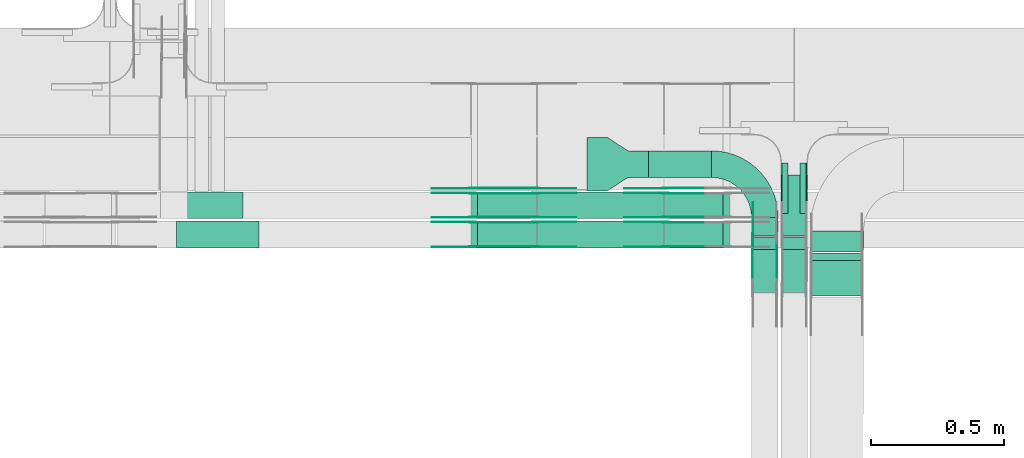
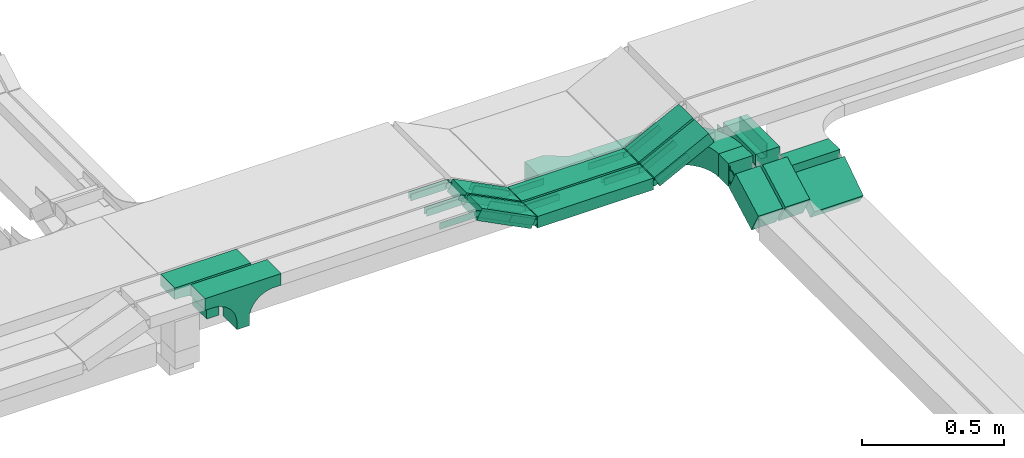
# One storey, part 22 of 27: 39 flow fittings, 13 flow segments.
"""IFC2X3 building model written with IfcOpenShell, lengths in millimetres."""

from ifc_helpers import new_model, entity, si_unit, converted_unit, derived_unit, direction, frame, frame_2d, origin, origin_2d_with_axis, place, context, subcontext, project, spatial, polyline, circle_curve, parameter, trimmed, segment, composite_curve, rectangle, outline, extrude, source, transform, mapped, material, type_object, type_shapes, element, save


model = new_model("IFC2X3")

# Units and contexts
model_context = context("Model", 3, precision=0.01, world=origin(), true_north=direction((6.12303176911189e-17, 1.0)))
body_context = subcontext(model_context, "Body", "Model", "MODEL_VIEW")
ifc_project = project(units=[si_unit("LENGTHUNIT", "METRE", prefix="MILLI"), si_unit("AREAUNIT", "SQUARE_METRE"), si_unit("VOLUMEUNIT", "CUBIC_METRE"), converted_unit("PLANEANGLEUNIT", "DEGREE", entity("IfcRatioMeasure", 0.0174532925199433), si_unit("PLANEANGLEUNIT", "RADIAN"), dimensions=[0, 0, 0, 0, 0, 0, 0]), si_unit("MASSUNIT", "GRAM", prefix="KILO"), derived_unit("MASSDENSITYUNIT", [(si_unit("MASSUNIT", "GRAM", prefix="KILO"), 1), (si_unit("LENGTHUNIT", "METRE"), -3)]), derived_unit("MOMENTOFINERTIAUNIT", [(si_unit("LENGTHUNIT", "METRE"), 4)]), si_unit("TIMEUNIT", "SECOND"), si_unit("FREQUENCYUNIT", "HERTZ"), si_unit("THERMODYNAMICTEMPERATUREUNIT", "DEGREE_CELSIUS"), derived_unit("THERMALTRANSMITTANCEUNIT", [(si_unit("MASSUNIT", "GRAM", prefix="KILO"), 1), (si_unit("THERMODYNAMICTEMPERATUREUNIT", "KELVIN"), -1), (si_unit("TIMEUNIT", "SECOND"), -3)]), derived_unit("VOLUMETRICFLOWRATEUNIT", [(si_unit("LENGTHUNIT", "METRE"), 3), (si_unit("TIMEUNIT", "SECOND"), -1)]), derived_unit("MASSFLOWRATEUNIT", [(si_unit("MASSUNIT", "GRAM", prefix="KILO"), 1), (si_unit("TIMEUNIT", "SECOND"), -1)]), derived_unit("ROTATIONALFREQUENCYUNIT", [(si_unit("TIMEUNIT", "SECOND"), -1)]), si_unit("ELECTRICCURRENTUNIT", "AMPERE"), si_unit("ELECTRICVOLTAGEUNIT", "VOLT"), si_unit("POWERUNIT", "WATT"), si_unit("FORCEUNIT", "NEWTON", prefix="KILO"), si_unit("ILLUMINANCEUNIT", "LUX"), si_unit("LUMINOUSFLUXUNIT", "LUMEN"), si_unit("LUMINOUSINTENSITYUNIT", "CANDELA"), derived_unit("USERDEFINED", [(si_unit("MASSUNIT", "GRAM", prefix="KILO"), -1), (si_unit("LENGTHUNIT", "METRE"), -2), (si_unit("TIMEUNIT", "SECOND"), 3), (si_unit("LUMINOUSFLUXUNIT", "LUMEN"), 1)]), derived_unit("LINEARVELOCITYUNIT", [(si_unit("LENGTHUNIT", "METRE"), 1), (si_unit("TIMEUNIT", "SECOND"), -1)]), si_unit("PRESSUREUNIT", "PASCAL"), derived_unit("USERDEFINED", [(si_unit("LENGTHUNIT", "METRE"), -2), (si_unit("MASSUNIT", "GRAM", prefix="KILO"), 1), (si_unit("TIMEUNIT", "SECOND"), -2)]), derived_unit("LINEARFORCEUNIT", [(si_unit("MASSUNIT", "GRAM", prefix="KILO"), 1), (si_unit("LENGTHUNIT", "METRE"), 1), (si_unit("TIMEUNIT", "SECOND"), -2), (si_unit("LENGTHUNIT", "METRE"), -1)]), derived_unit("PLANARFORCEUNIT", [(si_unit("MASSUNIT", "GRAM", prefix="KILO"), 1), (si_unit("LENGTHUNIT", "METRE"), 1), (si_unit("TIMEUNIT", "SECOND"), -2), (si_unit("LENGTHUNIT", "METRE"), -2)])], contexts=[model_context])

# Site, building, storey
site_placement = place(None, origin())
site = spatial("IfcSite", under=ifc_project, at=site_placement, CompositionType="ELEMENT")
building_placement = place(site_placement, origin())
building = spatial("IfcBuilding", under=site, at=building_placement, CompositionType="ELEMENT")
storey_placement = place(building_placement, origin())
storey = spatial("IfcBuildingStorey", under=building, at=storey_placement, CompositionType="ELEMENT", Elevation=0.0)

# Flow segments
cable_carrier_segment_type = type_object("IfcCableCarrierSegmentType", PredefinedType="CABLETRAYSEGMENT")
flow_segment_1_placement = place(storey_placement, frame((65838.17, 8564.33, 2600.0)))
element("IfcFlowSegment", 1, at=flow_segment_1_placement, inside=storey, type_object=cable_carrier_segment_type, context=body_context, shape_type="SweptSolid", body=[
    extrude(rectangle(XDim=235.827601762733, YDim=100.000000000001, at=origin_2d_with_axis()), frame((117.91, 50.0, 0.0)), (0.0, 0.0, 1.0), 100.0),
])
flow_segment_2_placement = place(storey_placement, frame((66225.0, 8344.23, 2600.0)))
element("IfcFlowSegment", 2, at=flow_segment_2_placement, inside=storey, type_object=cable_carrier_segment_type, context=body_context, shape_type="SweptSolid", body=[
    extrude(rectangle(XDim=69.0994138155711, YDim=99.9999999999946, at=origin_2d_with_axis()), frame((50.0, 34.55, 0.0), z_axis=(0.0, 0.0, 1.0), x_axis=(0.0, -1.0, 0.0)), (0.0, 0.0, 1.0), 100.0),
])
flow_segment_3_placement = place(storey_placement, frame((66225.0, 8133.28, 2512.93)))
element("IfcFlowSegment", 3, at=flow_segment_3_placement, inside=storey, type_object=cable_carrier_segment_type, context=body_context, shape_type="SweptSolid", body=[
    extrude(rectangle(XDim=100.0, YDim=99.9999999999946, at=origin_2d_with_axis()), frame((50.0, 23.73, 44.01), z_axis=(0.0, 0.880202910340005, 0.474597552278754), x_axis=(0.0, -0.474597552278754, 0.880202910340005)), (0.0, 0.0, 1.0), 181.443664845643),
])
flow_segment_4_placement = place(storey_placement, frame((66335.0, 8344.23, 2600.0)))
element("IfcFlowSegment", 4, at=flow_segment_4_placement, inside=storey, type_object=cable_carrier_segment_type, context=body_context, shape_type="SweptSolid", body=[
    extrude(rectangle(XDim=230.099413815084, YDim=99.9999999999946, at=origin_2d_with_axis()), frame((50.0, 115.05, 0.0), z_axis=(0.0, 0.0, 1.0), x_axis=(0.0, -1.0, 0.0)), (0.0, 0.0, 1.0), 100.0),
])
flow_segment_5_placement = place(storey_placement, frame((66335.0, 8133.28, 2512.93)))
element("IfcFlowSegment", 5, at=flow_segment_5_placement, inside=storey, type_object=cable_carrier_segment_type, context=body_context, shape_type="SweptSolid", body=[
    extrude(rectangle(XDim=99.9999999999998, YDim=99.9999999999946, at=origin_2d_with_axis()), frame((50.0, 23.73, 44.01), z_axis=(0.0, 0.880202910342462, 0.474597552274198), x_axis=(0.0, -0.474597552274198, 0.880202910342462)), (0.0, 0.0, 1.0), 181.443664845729),
])
flow_segment_6_placement = place(storey_placement, frame((66445.0, 8284.12, 2600.0)))
element("IfcFlowSegment", 6, at=flow_segment_6_placement, inside=storey, type_object=cable_carrier_segment_type, context=body_context, shape_type="SweptSolid", body=[
    extrude(rectangle(XDim=79.2028595795973, YDim=200.000000000007, at=origin_2d_with_axis()), frame((100.0, 39.6, 0.0), z_axis=(0.0, 0.0, 1.0), x_axis=(0.0, -1.0, 0.0)), (0.0, 0.0, 1.0), 49.9999999999995),
])
flow_segment_7_placement = place(storey_placement, frame((66445.0, 8118.93, 2509.66)))
element("IfcFlowSegment", 7, at=flow_segment_7_placement, inside=storey, type_object=cable_carrier_segment_type, context=body_context, shape_type="SweptSolid", body=[
    extrude(rectangle(XDim=49.9999999999992, YDim=160.399490584972, at=frame_2d((0.0, 0.0), x_axis=(0.0, 1.0))), frame((0.0, 80.57, 65.34), z_axis=(1.0, 0.0, 0.0), x_axis=(0.0, -0.831466573945081, -0.555574780215976)), (0.0, 0.0, 1.0), 200.000000000007),
])
flow_segment_8_placement = place(storey_placement, frame((65421.78, 8300.0, 2730.0)))
element("IfcFlowSegment", 8, at=flow_segment_8_placement, inside=storey, type_object=cable_carrier_segment_type, context=body_context, shape_type="SweptSolid", body=[
    extrude(rectangle(XDim=472.037715986993, YDim=100.000000000001, at=origin_2d_with_axis()), frame((236.02, 50.0, 0.0), z_axis=(0.0, 0.0, 1.0), x_axis=(-1.0, 0.0, 0.0)), (0.0, 0.0, 1.0), 50.0000000000005),
])
flow_segment_9_placement = place(storey_placement, frame((65897.53, 8300.0, 2736.34)))
element("IfcFlowSegment", 9, at=flow_segment_9_placement, inside=storey, type_object=cable_carrier_segment_type, context=body_context, shape_type="SweptSolid", body=[
    extrude(rectangle(XDim=49.9999999999994, YDim=99.9999999999989, at=frame_2d((0.0, 0.0), x_axis=(0.0, 1.0))), frame((11.35, 50.0, 22.28), z_axis=(0.89100652418826, 0.0, 0.453990499739758), x_axis=(0.0, 1.0, 0.0)), (0.0, 0.0, 1.0), 248.398143723743),
])
flow_segment_10_placement = place(storey_placement, frame((65174.05, 8300.0, 2736.34)))
element("IfcFlowSegment", 10, at=flow_segment_10_placement, inside=storey, type_object=cable_carrier_segment_type, context=body_context, shape_type="SweptSolid", body=[
    extrude(rectangle(XDim=50.0000000000027, YDim=99.9999999999989, at=origin_2d_with_axis()), frame((11.35, 50.0, 135.05), z_axis=(0.891006524188364, 0.0, -0.453990499739555), x_axis=(0.453990499739555, 0.0, 0.891006524188364)), (0.0, 0.0, 1.0), 248.39814372396),
])
flow_segment_11_placement = place(storey_placement, frame((65421.78, 8410.0, 2730.0)))
element("IfcFlowSegment", 11, at=flow_segment_11_placement, inside=storey, type_object=cable_carrier_segment_type, context=body_context, shape_type="SweptSolid", body=[
    extrude(rectangle(XDim=472.037715986993, YDim=99.9999999999989, at=origin_2d_with_axis()), frame((236.02, 50.0, 0.0), z_axis=(0.0, 0.0, 1.0), x_axis=(-1.0, 0.0, 0.0)), (0.0, 0.0, 1.0), 50.0000000000005),
])
flow_segment_12_placement = place(storey_placement, frame((65897.53, 8410.0, 2736.34)))
element("IfcFlowSegment", 12, at=flow_segment_12_placement, inside=storey, type_object=cable_carrier_segment_type, context=body_context, shape_type="SweptSolid", body=[
    extrude(rectangle(XDim=50.0000000000027, YDim=100.000000000001, at=frame_2d((0.0, 0.0), x_axis=(0.0, 1.0))), frame((11.35, 50.0, 22.28), z_axis=(0.891006524188364, 0.0, 0.453990499739555), x_axis=(0.0, 1.0, 0.0)), (0.0, 0.0, 1.0), 248.39814372396),
])
flow_segment_13_placement = place(storey_placement, frame((65174.05, 8410.0, 2736.34)))
element("IfcFlowSegment", 13, at=flow_segment_13_placement, inside=storey, type_object=cable_carrier_segment_type, context=body_context, shape_type="SweptSolid", body=[
    extrude(rectangle(XDim=49.9999999999978, YDim=100.000000000001, at=origin_2d_with_axis()), frame((11.35, 50.0, 135.05), z_axis=(0.891006524188517, 0.0, -0.453990499739253), x_axis=(0.453990499739253, 0.0, 0.891006524188517)), (0.0, 0.0, 1.0), 248.398143724083),
])

# Flow fittings
ifc_material_1 = material()
cable_carrier_fitting_type_1 = type_object("IfcCableCarrierFittingType", PredefinedType="NOTDEFINED", material=ifc_material_1)
shared_shape_1 = source(origin(), body_context, "Body", "SweptSolid", [
    extrude(outline(polyline([(-9.17, -21.5), (15.83, -21.5), (15.83, -19.0), (-6.67, -19.0), (-6.67, 40.5), (-9.17, 40.5), (-9.17, -21.5)])), frame((-95.0, 9.17, -26.0), z_axis=(1.0, 0.0, 0.0), x_axis=(0.0, 1.0, 0.0)), (0.0, 0.0, 1.0), 190.0),
])
type_shapes(cable_carrier_fitting_type_1, [shared_shape_1])
for number, where, z_axis, x_axis in (
    (14, (66432.5, 8524.33, 2650.0), (0.0, 0.0, 1.0), (0.0, 1.0, 0.0)),
    (15, (66337.5, 8524.33, 2650.0), (0.0, 0.0, 1.0), (0.0, -1.0, 0.0)),
):
    element("IfcFlowFitting", number, at=place(storey_placement, frame(where, z_axis=z_axis, x_axis=x_axis)), inside=storey, type_object=cable_carrier_fitting_type_1, material=ifc_material_1, context=body_context, shape_type="MappedRepresentation", body=[
        mapped(shared_shape_1, transform((0.0, 0.0, 0.0), scale=1.0)),
    ])
ifc_material_2 = material()
cable_carrier_fitting_type_2 = type_object("IfcCableCarrierFittingType", PredefinedType="NOTDEFINED", material=ifc_material_2)
shared_shape_2 = source(origin(), body_context, "Body", "SweptSolid", [
    extrude(outline(polyline([(-115.0, 50.0), (-115.0, -50.0), (-38.33, -50.0), (38.33, -100.0), (115.0, -100.0), (115.0, 100.0), (38.33, 100.0), (-38.33, 50.0), (-115.0, 50.0)])), frame((115.0, 0.0, -50.0), z_axis=(0.0, 0.0, -1.0), x_axis=(1.0, 0.0, 0.0)), (0.0, 0.0, -1.0), 100.0),
])
type_shapes(cable_carrier_fitting_type_2, [shared_shape_2])
flow_fitting_1_placement = place(storey_placement, frame((65838.17, 8614.33, 2650.0), z_axis=(0.0, 0.0, 1.0), x_axis=(-1.0, 0.0, 0.0)))
element("IfcFlowFitting", 16, at=flow_fitting_1_placement, inside=storey, type_object=cable_carrier_fitting_type_2, material=ifc_material_2, Name="470_DKC_S5_adapter", context=body_context, shape_type="MappedRepresentation", body=[
    mapped(shared_shape_2, transform((0.0, 0.0, 0.0), scale=1.0)),
])
ifc_material_3 = material(Name="G")
cable_carrier_fitting_type_3 = type_object("IfcCableCarrierFittingType", PredefinedType="NOTDEFINED", material=ifc_material_3)
shared_shape_3 = source(origin(), body_context, "Body", "SweptSolid", [
    extrude(outline(composite_curve([segment(trimmed(circle_curve(frame_2d((-44.59, 0.0), x_axis=(1.0, 0.0)), 12.5), [parameter(90.0000000000007)], [parameter(270.0)], True, "PARAMETER"), True, "CONTINUOUS"), segment(polyline([(-44.59, -12.5), (-33.09, -12.5)]), True, "CONTINUOUS"), segment(polyline([(-33.09, -12.5), (-31.23, -14.5)]), True, "CONTINUOUS"), segment(polyline([(-31.23, -14.5), (108.91, -14.5)]), True, "CONTINUOUS"), segment(polyline([(108.91, -14.5), (108.91, 14.5)]), True, "CONTINUOUS"), segment(polyline([(108.91, 14.5), (-31.23, 14.5)]), True, "CONTINUOUS"), segment(polyline([(-31.23, 14.5), (-33.09, 12.5)]), True, "CONTINUOUS"), segment(polyline([(-33.09, 12.5), (-44.59, 12.5)]), True, "CONTINUOUS")], self_intersect=False)), frame((44.59, 0.0, 0.0), z_axis=(0.0, 0.0, -1.0), x_axis=(1.0, 0.0, 0.0)), (0.0, 0.0, -1.0), 2.0),
])
type_shapes(cable_carrier_fitting_type_3, [shared_shape_3])
flow_fitting_2_placement = place(storey_placement, frame((65901.78, 8395.46, 2755.0), z_axis=(0.0, 1.0, 0.0), x_axis=(-1.0, 0.0, 0.0)))
element("IfcFlowFitting", 17, at=flow_fitting_2_placement, inside=storey, type_object=cable_carrier_fitting_type_3, material=ifc_material_3, context=body_context, shape_type="MappedRepresentation", body=[
    mapped(shared_shape_3, transform((0.0, 0.0, 0.0), scale=1.0)),
])
cable_carrier_fitting_type_4 = type_object("IfcCableCarrierFittingType", PredefinedType="NOTDEFINED", material=ifc_material_3)
type_shapes(cable_carrier_fitting_type_4, [shared_shape_3])
flow_fitting_3_placement = place(storey_placement, frame((65901.78, 8306.54, 2755.0), z_axis=(0.0, -1.0, 0.0), x_axis=(0.891006524188259, 0.0, 0.45399049973976)))
element("IfcFlowFitting", 18, at=flow_fitting_3_placement, inside=storey, type_object=cable_carrier_fitting_type_4, material=ifc_material_3, context=body_context, shape_type="MappedRepresentation", body=[
    mapped(shared_shape_3, transform((0.0, 0.0, 0.0), scale=1.0)),
])
flow_fitting_4_placement = place(storey_placement, frame((65413.82, 8304.54, 2755.0), z_axis=(0.0, -1.0, 0.0), x_axis=(1.0, 0.0, 0.0)))
element("IfcFlowFitting", 19, at=flow_fitting_4_placement, inside=storey, type_object=cable_carrier_fitting_type_3, material=ifc_material_3, context=body_context, shape_type="MappedRepresentation", body=[
    mapped(shared_shape_3, transform((0.0, 0.0, 0.0), scale=1.0)),
])
flow_fitting_5_placement = place(storey_placement, frame((65413.82, 8393.46, 2755.0), z_axis=(0.0, 1.0, 0.0), x_axis=(-0.891006524188259, 0.0, 0.45399049973976)))
element("IfcFlowFitting", 20, at=flow_fitting_5_placement, inside=storey, type_object=cable_carrier_fitting_type_4, material=ifc_material_3, context=body_context, shape_type="MappedRepresentation", body=[
    mapped(shared_shape_3, transform((0.0, 0.0, 0.0), scale=1.0)),
])
flow_fitting_6_placement = place(storey_placement, frame((65178.31, 8304.54, 2875.0), z_axis=(0.0, -1.0, 0.0), x_axis=(-1.0, 0.0, 0.0)))
element("IfcFlowFitting", 21, at=flow_fitting_6_placement, inside=storey, type_object=cable_carrier_fitting_type_3, material=ifc_material_3, context=body_context, shape_type="MappedRepresentation", body=[
    mapped(shared_shape_3, transform((0.0, 0.0, 0.0), scale=1.0)),
])
flow_fitting_7_placement = place(storey_placement, frame((65178.31, 8393.46, 2875.0), z_axis=(0.0, 1.0, 0.0), x_axis=(0.891006524188393, 0.0, -0.453990499739498)))
element("IfcFlowFitting", 22, at=flow_fitting_7_placement, inside=storey, type_object=cable_carrier_fitting_type_4, material=ifc_material_3, context=body_context, shape_type="MappedRepresentation", body=[
    mapped(shared_shape_3, transform((0.0, 0.0, 0.0), scale=1.0)),
])
flow_fitting_8_placement = place(storey_placement, frame((65901.78, 8505.46, 2755.0), z_axis=(0.0, 1.0, 0.0), x_axis=(-1.0, 0.0, 0.0)))
element("IfcFlowFitting", 23, at=flow_fitting_8_placement, inside=storey, type_object=cable_carrier_fitting_type_3, material=ifc_material_3, context=body_context, shape_type="MappedRepresentation", body=[
    mapped(shared_shape_3, transform((0.0, 0.0, 0.0), scale=1.0)),
])
flow_fitting_9_placement = place(storey_placement, frame((65901.78, 8416.54, 2755.0), z_axis=(0.0, -1.0, 0.0), x_axis=(0.891006524188259, 0.0, 0.45399049973976)))
element("IfcFlowFitting", 24, at=flow_fitting_9_placement, inside=storey, type_object=cable_carrier_fitting_type_4, material=ifc_material_3, context=body_context, shape_type="MappedRepresentation", body=[
    mapped(shared_shape_3, transform((0.0, 0.0, 0.0), scale=1.0)),
])
flow_fitting_10_placement = place(storey_placement, frame((65413.82, 8414.54, 2755.0), z_axis=(0.0, -1.0, 0.0), x_axis=(1.0, 0.0, 0.0)))
element("IfcFlowFitting", 25, at=flow_fitting_10_placement, inside=storey, type_object=cable_carrier_fitting_type_3, material=ifc_material_3, context=body_context, shape_type="MappedRepresentation", body=[
    mapped(shared_shape_3, transform((0.0, 0.0, 0.0), scale=1.0)),
])
for number, where, z_axis, x_axis in (
    (26, (65413.82, 8503.46, 2755.0), (0.0, 1.0, 0.0), (-0.891006524188259, 0.0, 0.45399049973976)),
    (27, (65901.78, 8526.54, 2755.0), (0.0, -1.0, 0.0), (0.891006524188259, 0.0, 0.45399049973976)),
):
    element("IfcFlowFitting", number, at=place(storey_placement, frame(where, z_axis=z_axis, x_axis=x_axis)), inside=storey, type_object=cable_carrier_fitting_type_4, material=ifc_material_3, context=body_context, shape_type="MappedRepresentation", body=[
        mapped(shared_shape_3, transform((0.0, 0.0, 0.0), scale=1.0)),
    ])
for number, where, z_axis, x_axis in (
    (28, (65413.82, 8524.54, 2755.0), (0.0, -1.0, 0.0), (1.0, 0.0, 0.0)),
    (29, (65178.31, 8524.54, 2875.0), (0.0, -1.0, 0.0), (-1.0, 0.0, 0.0)),
    (30, (65178.31, 8414.54, 2875.0), (0.0, -1.0, 0.0), (-1.0, 0.0, 0.0)),
):
    element("IfcFlowFitting", number, at=place(storey_placement, frame(where, z_axis=z_axis, x_axis=x_axis)), inside=storey, type_object=cable_carrier_fitting_type_3, material=ifc_material_3, context=body_context, shape_type="MappedRepresentation", body=[
        mapped(shared_shape_3, transform((0.0, 0.0, 0.0), scale=1.0)),
    ])
flow_fitting_11_placement = place(storey_placement, frame((65178.31, 8503.46, 2875.0), z_axis=(0.0, 1.0, 0.0), x_axis=(0.891006524188516, 0.0, -0.453990499739256)))
element("IfcFlowFitting", 31, at=flow_fitting_11_placement, inside=storey, type_object=cable_carrier_fitting_type_4, material=ifc_material_3, context=body_context, shape_type="MappedRepresentation", body=[
    mapped(shared_shape_3, transform((0.0, 0.0, 0.0), scale=1.0)),
])
cable_carrier_fitting_type_5 = type_object("IfcCableCarrierFittingType", PredefinedType="NOTDEFINED", material=ifc_material_3)
shared_shape_4 = source(origin(), body_context, "Body", "SweptSolid", [
    extrude(outline(composite_curve([segment(trimmed(circle_curve(frame_2d((-44.59, 0.0), x_axis=(1.0, 0.0)), 12.5), [parameter(90.0000000000007)], [parameter(270.0)], True, "PARAMETER"), True, "CONTINUOUS"), segment(polyline([(-44.59, -12.5), (-33.09, -12.5)]), True, "CONTINUOUS"), segment(polyline([(-33.09, -12.5), (-31.23, -14.5)]), True, "CONTINUOUS"), segment(polyline([(-31.23, -14.5), (108.91, -14.5)]), True, "CONTINUOUS"), segment(polyline([(108.91, -14.5), (108.91, 14.5)]), True, "CONTINUOUS"), segment(polyline([(108.91, 14.5), (-31.23, 14.5)]), True, "CONTINUOUS"), segment(polyline([(-31.23, 14.5), (-33.09, 12.5)]), True, "CONTINUOUS"), segment(polyline([(-33.09, 12.5), (-44.59, 12.5)]), True, "CONTINUOUS")], self_intersect=False)), frame((44.59, 0.0, 0.0)), (0.0, 0.0, 1.0), 2.0),
])
type_shapes(cable_carrier_fitting_type_5, [shared_shape_4])
flow_fitting_12_placement = place(storey_placement, frame((65901.78, 8304.54, 2755.0), z_axis=(0.0, -1.0, 0.0), x_axis=(-1.0, 0.0, 0.0)))
element("IfcFlowFitting", 32, at=flow_fitting_12_placement, inside=storey, type_object=cable_carrier_fitting_type_5, material=ifc_material_3, context=body_context, shape_type="MappedRepresentation", body=[
    mapped(shared_shape_4, transform((0.0, 0.0, 0.0), scale=1.0)),
])
cable_carrier_fitting_type_6 = type_object("IfcCableCarrierFittingType", PredefinedType="NOTDEFINED", material=ifc_material_3)
type_shapes(cable_carrier_fitting_type_6, [shared_shape_4])
flow_fitting_13_placement = place(storey_placement, frame((65901.78, 8393.46, 2755.0), z_axis=(0.0, 1.0, 0.0), x_axis=(0.891006524188259, 0.0, 0.45399049973976)))
element("IfcFlowFitting", 33, at=flow_fitting_13_placement, inside=storey, type_object=cable_carrier_fitting_type_6, material=ifc_material_3, context=body_context, shape_type="MappedRepresentation", body=[
    mapped(shared_shape_4, transform((0.0, 0.0, 0.0), scale=1.0)),
])
flow_fitting_14_placement = place(storey_placement, frame((65413.82, 8395.46, 2755.0), z_axis=(0.0, 1.0, 0.0), x_axis=(1.0, 0.0, 0.0)))
element("IfcFlowFitting", 34, at=flow_fitting_14_placement, inside=storey, type_object=cable_carrier_fitting_type_5, material=ifc_material_3, context=body_context, shape_type="MappedRepresentation", body=[
    mapped(shared_shape_4, transform((0.0, 0.0, 0.0), scale=1.0)),
])
flow_fitting_15_placement = place(storey_placement, frame((65413.82, 8306.54, 2755.0), z_axis=(0.0, -1.0, 0.0), x_axis=(-0.891006524188259, 0.0, 0.45399049973976)))
element("IfcFlowFitting", 35, at=flow_fitting_15_placement, inside=storey, type_object=cable_carrier_fitting_type_6, material=ifc_material_3, context=body_context, shape_type="MappedRepresentation", body=[
    mapped(shared_shape_4, transform((0.0, 0.0, 0.0), scale=1.0)),
])
flow_fitting_16_placement = place(storey_placement, frame((65178.31, 8395.46, 2875.0), z_axis=(0.0, 1.0, 0.0), x_axis=(-1.0, 0.0, 0.0)))
element("IfcFlowFitting", 36, at=flow_fitting_16_placement, inside=storey, type_object=cable_carrier_fitting_type_5, material=ifc_material_3, context=body_context, shape_type="MappedRepresentation", body=[
    mapped(shared_shape_4, transform((0.0, 0.0, 0.0), scale=1.0)),
])
flow_fitting_17_placement = place(storey_placement, frame((65178.31, 8306.54, 2875.0), z_axis=(0.0, -1.0, 0.0), x_axis=(0.891006524188393, 0.0, -0.453990499739498)))
element("IfcFlowFitting", 37, at=flow_fitting_17_placement, inside=storey, type_object=cable_carrier_fitting_type_6, material=ifc_material_3, context=body_context, shape_type="MappedRepresentation", body=[
    mapped(shared_shape_4, transform((0.0, 0.0, 0.0), scale=1.0)),
])
flow_fitting_18_placement = place(storey_placement, frame((65901.78, 8414.54, 2755.0), z_axis=(0.0, -1.0, 0.0), x_axis=(-1.0, 0.0, 0.0)))
element("IfcFlowFitting", 38, at=flow_fitting_18_placement, inside=storey, type_object=cable_carrier_fitting_type_5, material=ifc_material_3, context=body_context, shape_type="MappedRepresentation", body=[
    mapped(shared_shape_4, transform((0.0, 0.0, 0.0), scale=1.0)),
])
flow_fitting_19_placement = place(storey_placement, frame((65901.78, 8503.46, 2755.0), z_axis=(0.0, 1.0, 0.0), x_axis=(0.891006524188259, 0.0, 0.45399049973976)))
element("IfcFlowFitting", 39, at=flow_fitting_19_placement, inside=storey, type_object=cable_carrier_fitting_type_6, material=ifc_material_3, context=body_context, shape_type="MappedRepresentation", body=[
    mapped(shared_shape_4, transform((0.0, 0.0, 0.0), scale=1.0)),
])
flow_fitting_20_placement = place(storey_placement, frame((65413.82, 8505.46, 2755.0), z_axis=(0.0, 1.0, 0.0), x_axis=(1.0, 0.0, 0.0)))
element("IfcFlowFitting", 40, at=flow_fitting_20_placement, inside=storey, type_object=cable_carrier_fitting_type_5, material=ifc_material_3, context=body_context, shape_type="MappedRepresentation", body=[
    mapped(shared_shape_4, transform((0.0, 0.0, 0.0), scale=1.0)),
])
flow_fitting_21_placement = place(storey_placement, frame((65413.82, 8416.54, 2755.0), z_axis=(0.0, -1.0, 0.0), x_axis=(-0.891006524188259, 0.0, 0.45399049973976)))
element("IfcFlowFitting", 41, at=flow_fitting_21_placement, inside=storey, type_object=cable_carrier_fitting_type_6, material=ifc_material_3, context=body_context, shape_type="MappedRepresentation", body=[
    mapped(shared_shape_4, transform((0.0, 0.0, 0.0), scale=1.0)),
])
flow_fitting_22_placement = place(storey_placement, frame((65901.78, 8524.54, 2755.0), z_axis=(0.0, -1.0, 0.0), x_axis=(-1.0, 0.0, 0.0)))
element("IfcFlowFitting", 42, at=flow_fitting_22_placement, inside=storey, type_object=cable_carrier_fitting_type_5, material=ifc_material_3, context=body_context, shape_type="MappedRepresentation", body=[
    mapped(shared_shape_4, transform((0.0, 0.0, 0.0), scale=1.0)),
])
for number, where, z_axis, x_axis in (
    (43, (65413.82, 8526.54, 2755.0), (0.0, -1.0, 0.0), (-0.891006524188259, 0.0, 0.45399049973976)),
    (44, (65178.31, 8526.54, 2875.0), (0.0, -1.0, 0.0), (0.891006524188515, 0.0, -0.453990499739259)),
):
    element("IfcFlowFitting", number, at=place(storey_placement, frame(where, z_axis=z_axis, x_axis=x_axis)), inside=storey, type_object=cable_carrier_fitting_type_6, material=ifc_material_3, context=body_context, shape_type="MappedRepresentation", body=[
        mapped(shared_shape_4, transform((0.0, 0.0, 0.0), scale=1.0)),
    ])
flow_fitting_23_placement = place(storey_placement, frame((65178.31, 8505.46, 2875.0), z_axis=(0.0, 1.0, 0.0), x_axis=(-1.0, 0.0, 0.0)))
element("IfcFlowFitting", 45, at=flow_fitting_23_placement, inside=storey, type_object=cable_carrier_fitting_type_5, material=ifc_material_3, context=body_context, shape_type="MappedRepresentation", body=[
    mapped(shared_shape_4, transform((0.0, 0.0, 0.0), scale=1.0)),
])
flow_fitting_24_placement = place(storey_placement, frame((65178.31, 8416.54, 2875.0), z_axis=(0.0, -1.0, 0.0), x_axis=(0.891006524188516, 0.0, -0.453990499739256)))
element("IfcFlowFitting", 46, at=flow_fitting_24_placement, inside=storey, type_object=cable_carrier_fitting_type_6, material=ifc_material_3, context=body_context, shape_type="MappedRepresentation", body=[
    mapped(shared_shape_4, transform((0.0, 0.0, 0.0), scale=1.0)),
])
cable_carrier_fitting_type_7 = type_object("IfcCableCarrierFittingType", Name="470_DKC_S5_Variable Angle Elbow 0-45:-", PredefinedType="NOTDEFINED", material=ifc_material_2)
shared_shape_5 = source(origin(), body_context, "Body", "SweptSolid", [
    extrude(outline(composite_curve([segment(polyline([(-100.75, -150.25), (-99.75, -150.25)]), True, "CONTINUOUS"), segment(trimmed(circle_curve(frame_2d((-99.75, 99.75), x_axis=(0.0, -1.0)), 250.0), [parameter(0.0)], [parameter(90.0000000000001)], True, "PARAMETER"), True, "CONTINUOUS"), segment(polyline([(150.25, 99.75), (150.25, 100.75)]), True, "CONTINUOUS"), segment(polyline([(150.25, 100.75), (50.25, 100.75)]), True, "CONTINUOUS"), segment(polyline([(50.25, 100.75), (50.25, 99.75)]), True, "CONTINUOUS"), segment(trimmed(circle_curve(frame_2d((-99.75, 99.75), x_axis=(0.0, -1.0)), 150.0), [parameter(0.0)], [parameter(90.0000000000001)], True, "PARAMETER"), False, "CONTINUOUS"), segment(polyline([(-99.75, -50.25), (-100.75, -50.25)]), True, "CONTINUOUS"), segment(polyline([(-100.75, -50.25), (-100.75, -150.25)]), True, "CONTINUOUS")], self_intersect=False)), frame((-100.25, 100.25, -50.0)), (0.0, 0.0, 1.0), 100.0),
])
type_shapes(cable_carrier_fitting_type_7, [shared_shape_5])
flow_fitting_25_placement = place(storey_placement, frame((66275.0, 8614.33, 2650.0), z_axis=(0.0, 0.0, 1.0), x_axis=(0.0, 1.0, 0.0)))
element("IfcFlowFitting", 47, at=flow_fitting_25_placement, inside=storey, type_object=cable_carrier_fitting_type_7, material=ifc_material_2, Name="470_DKC_S5_Variable Angle Elbow 0-45:-", ObjectType="470_DKC_S5_Variable Angle Elbow 0-45:-", context=body_context, shape_type="MappedRepresentation", body=[
    mapped(shared_shape_5, transform((0.0, 0.0, 0.0), scale=1.0)),
])
cable_carrier_fitting_type_8 = type_object("IfcCableCarrierFittingType", PredefinedType="NOTDEFINED", material=ifc_material_3)
shared_shape_6 = source(origin(), body_context, "Body", "SweptSolid", [
    extrude(outline(composite_curve([segment(trimmed(circle_curve(frame_2d((-41.47, 0.0), x_axis=(1.0, 0.0)), 25.0), [parameter(90.0000000000007)], [parameter(270.0)], True, "PARAMETER"), True, "CONTINUOUS"), segment(polyline([(-41.47, -25.0), (-29.97, -25.0)]), True, "CONTINUOUS"), segment(polyline([(-29.97, -25.0), (-28.1, -38.5)]), True, "CONTINUOUS"), segment(polyline([(-28.1, -38.5), (99.53, -38.5)]), True, "CONTINUOUS"), segment(polyline([(99.53, -38.5), (99.53, 38.5)]), True, "CONTINUOUS"), segment(polyline([(99.53, 38.5), (-28.1, 38.5)]), True, "CONTINUOUS"), segment(polyline([(-28.1, 38.5), (-29.97, 25.0)]), True, "CONTINUOUS"), segment(polyline([(-29.97, 25.0), (-41.47, 25.0)]), True, "CONTINUOUS")], self_intersect=False)), frame((41.47, 0.0, 0.0), z_axis=(0.0, 0.0, -1.0), x_axis=(1.0, 0.0, 0.0)), (0.0, 0.0, -1.0), 2.0),
])
type_shapes(cable_carrier_fitting_type_8, [shared_shape_6])
flow_fitting_26_placement = place(storey_placement, frame((66320.46, 8329.6, 2650.0), z_axis=(1.0, 0.0, 0.0), x_axis=(0.0, -0.880202910340009, -0.474597552278748)))
element("IfcFlowFitting", 48, at=flow_fitting_26_placement, inside=storey, type_object=cable_carrier_fitting_type_8, material=ifc_material_3, context=body_context, shape_type="MappedRepresentation", body=[
    mapped(shared_shape_6, transform((0.0, 0.0, 0.0), scale=1.0)),
])
cable_carrier_fitting_type_9 = type_object("IfcCableCarrierFittingType", PredefinedType="NOTDEFINED", material=ifc_material_3)
type_shapes(cable_carrier_fitting_type_9, [shared_shape_6])
flow_fitting_27_placement = place(storey_placement, frame((66231.54, 8329.6, 2650.0), z_axis=(-1.0, 0.0, 0.0), x_axis=(0.0, 1.0, 0.0)))
element("IfcFlowFitting", 49, at=flow_fitting_27_placement, inside=storey, type_object=cable_carrier_fitting_type_9, material=ifc_material_3, context=body_context, shape_type="MappedRepresentation", body=[
    mapped(shared_shape_6, transform((0.0, 0.0, 0.0), scale=1.0)),
])
cable_carrier_fitting_type_10 = type_object("IfcCableCarrierFittingType", PredefinedType="NOTDEFINED", material=ifc_material_3)
shared_shape_7 = source(origin(), body_context, "Body", "SweptSolid", [
    extrude(outline(composite_curve([segment(trimmed(circle_curve(frame_2d((-41.47, 0.0), x_axis=(1.0, 0.0)), 25.0), [parameter(90.0000000000007)], [parameter(270.0)], True, "PARAMETER"), True, "CONTINUOUS"), segment(polyline([(-41.47, -25.0), (-29.97, -25.0)]), True, "CONTINUOUS"), segment(polyline([(-29.97, -25.0), (-28.1, -38.5)]), True, "CONTINUOUS"), segment(polyline([(-28.1, -38.5), (99.53, -38.5)]), True, "CONTINUOUS"), segment(polyline([(99.53, -38.5), (99.53, 38.5)]), True, "CONTINUOUS"), segment(polyline([(99.53, 38.5), (-28.1, 38.5)]), True, "CONTINUOUS"), segment(polyline([(-28.1, 38.5), (-29.97, 25.0)]), True, "CONTINUOUS"), segment(polyline([(-29.97, 25.0), (-41.47, 25.0)]), True, "CONTINUOUS")], self_intersect=False)), frame((41.47, 0.0, 0.0)), (0.0, 0.0, 1.0), 2.0),
])
type_shapes(cable_carrier_fitting_type_10, [shared_shape_7])
flow_fitting_28_placement = place(storey_placement, frame((66229.54, 8329.6, 2650.0), z_axis=(-1.0, 0.0, 0.0), x_axis=(0.0, -0.880202910340009, -0.474597552278748)))
element("IfcFlowFitting", 50, at=flow_fitting_28_placement, inside=storey, type_object=cable_carrier_fitting_type_10, material=ifc_material_3, context=body_context, shape_type="MappedRepresentation", body=[
    mapped(shared_shape_7, transform((0.0, 0.0, 0.0), scale=1.0)),
])
cable_carrier_fitting_type_11 = type_object("IfcCableCarrierFittingType", PredefinedType="NOTDEFINED", material=ifc_material_2)
shared_shape_8 = source(origin(), body_context, "Body", "SweptSolid", [
    extrude(outline(composite_curve([segment(polyline([(-155.0, -85.8), (155.0, -85.8)]), True, "CONTINUOUS"), segment(polyline([(155.0, -85.8), (155.0, -35.8)]), True, "CONTINUOUS"), segment(polyline([(155.0, -35.8), (125.0, -35.8)]), True, "CONTINUOUS"), segment(trimmed(circle_curve(frame_2d((125.0, 64.2), x_axis=(1.0, 0.0)), 99.9999999999926), [parameter(180.0)], [parameter(269.999999999985)], True, "PARAMETER"), False, "CONTINUOUS"), segment(polyline([(25.0, 64.2), (25.0, 93.2)]), True, "CONTINUOUS"), segment(polyline([(25.0, 93.2), (-25.0, 93.2)]), True, "CONTINUOUS"), segment(polyline([(-25.0, 93.2), (-25.0, 64.2)]), True, "CONTINUOUS"), segment(trimmed(circle_curve(frame_2d((-125.0, 64.2), x_axis=(1.0, 0.0)), 99.9999999999768), [parameter(270.0)], [parameter(359.999999999955)], True, "PARAMETER"), False, "CONTINUOUS"), segment(polyline([(-125.0, -35.8), (-155.0, -35.8)]), True, "CONTINUOUS"), segment(polyline([(-155.0, -35.8), (-155.0, -85.8)]), True, "CONTINUOUS")], self_intersect=False)), frame((155.0, -50.0, -60.8), z_axis=(0.0, 1.0, 0.0), x_axis=(1.0, 0.0, 0.0)), (0.0, 0.0, 1.0), 100.0),
])
type_shapes(cable_carrier_fitting_type_11, [shared_shape_8])
for number, where, z_axis, x_axis in (
    (51, (64317.17, 8460.0, 2875.0), (0.0, 0.0, 1.0), (-1.0, 0.0, 0.0)),
    (52, (64377.32, 8350.0, 2875.0), (0.0, 0.0, 1.0), (-1.0, 0.0, 0.0)),
):
    element("IfcFlowFitting", number, at=place(storey_placement, frame(where, z_axis=z_axis, x_axis=x_axis)), inside=storey, type_object=cable_carrier_fitting_type_11, material=ifc_material_2, context=body_context, shape_type="MappedRepresentation", body=[
        mapped(shared_shape_8, transform((0.0, 0.0, 0.0), scale=1.0)),
    ])

save(model, "model.ifc")
